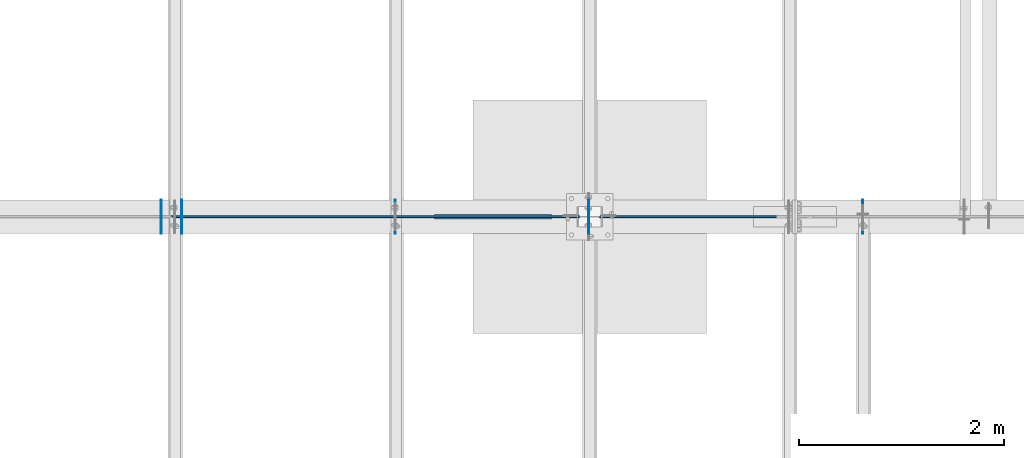
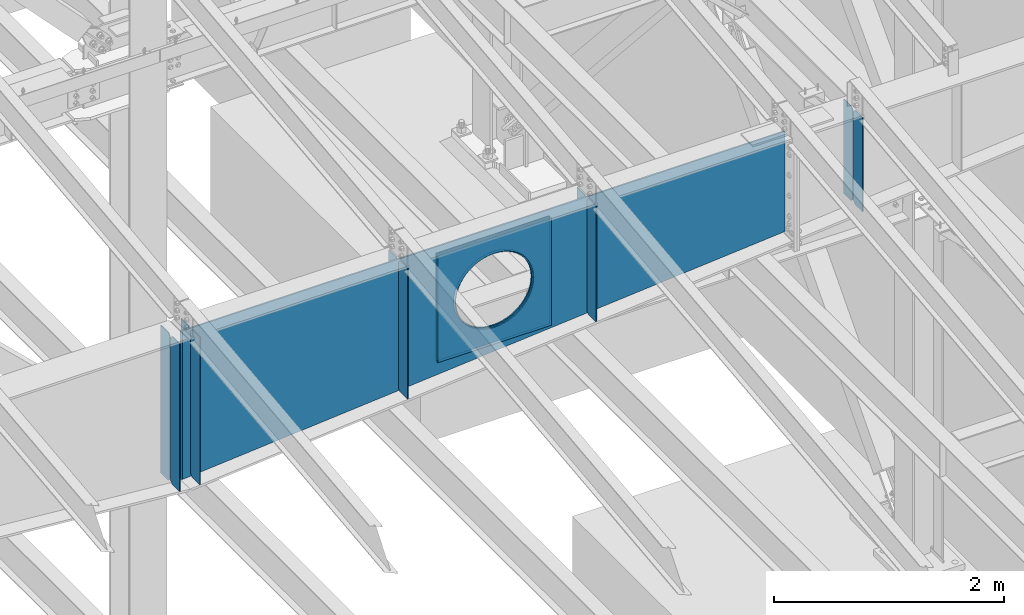
# One storey, part 974 of 1179: 13 plates, 2 elements without a shape of their own.
"""IFC2X3 building model written with IfcOpenShell, lengths in millimetres."""

from ifc_helpers import new_model, si_unit, frame, origin_with_axes, place, context, subcontext, project, spatial, faceted_brep, material, type_object, element, aggregate, save


model = new_model("IFC2X3")

# Units and contexts
model_context = context("Model", 3, precision=1e-05, world=origin_with_axes())
body_context = subcontext(model_context, "Body", "Model", "MODEL_VIEW")
ifc_project = project(units=[si_unit("LENGTHUNIT", "METRE", prefix="MILLI"), si_unit("AREAUNIT", "SQUARE_METRE"), si_unit("VOLUMEUNIT", "CUBIC_METRE"), si_unit("MASSUNIT", "GRAM", prefix="KILO"), si_unit("TIMEUNIT", "SECOND"), si_unit("PLANEANGLEUNIT", "RADIAN"), si_unit("SOLIDANGLEUNIT", "STERADIAN"), si_unit("THERMODYNAMICTEMPERATUREUNIT", "DEGREE_CELSIUS"), si_unit("LUMINOUSINTENSITYUNIT", "LUMEN")], contexts=[model_context])

# Site, building, storey
site_placement = place(None, origin_with_axes())
site = spatial("IfcSite", under=ifc_project, at=site_placement, CompositionType="ELEMENT")
building_placement = place(site_placement, origin_with_axes())
building = spatial("IfcBuilding", under=site, at=building_placement, Name="Undefined", CompositionType="ELEMENT")
storey_placement = place(building_placement, origin_with_axes())
storey = spatial("IfcBuildingStorey", under=building, at=storey_placement, Name="Undefined", CompositionType="ELEMENT", Elevation=0.0)

# Assembly, plates
assembly_1_placement = place(storey_placement, origin_with_axes())
assembly_1 = element("IfcElementAssembly", 1, at=assembly_1_placement, inside=storey, Name="RAFTER BEAM", AssemblyPlace="NOTDEFINED", PredefinedType="RIGID_FRAME")
ifc_material = material(Name="STEEL/A36")
plate_type_1 = type_object("IfcPlateType", PredefinedType="NOTDEFINED")
plate_1_placement = place(assembly_1_placement, frame((19130.9625, 19392.8999999624, 11103.7687496185), z_axis=(0.0, 0.0, -1.0), x_axis=(0.0, -1.0, 0.0)))
plate_1 = element("IfcPlate", 2, at=plate_1_placement, type_object=plate_type_1, material=ifc_material, Name="PLATE", context=body_context, shape_type="Brep", body=[
    faceted_brep([(0.0, -4.76249999999709, 0.0), (-2.26062911679037e-06, -4.76250000000073, 1000.58386493601), (-2.26062911679037e-06, 4.76250000000073, 1000.58386493601), (0.0, 4.76249999999709, 0.0), (131.762498120836, -4.76250000000073, 1000.58386525562), (131.762498120836, 4.76250000000073, 1000.58386525562), (157.162497796751, -4.76250000000073, 975.1838656987), (157.162497796751, 4.76250000000073, 975.1838656987), (157.162499942613, -4.76250000000073, 25.3999996182793), (157.162499942613, 4.76250000000073, 25.3999996182793), (131.762500381465, -4.76250000000073, -2.09183781407773e-10), (131.762500381465, 4.76250000000073, -2.09183781407773e-10)], [[[0, 1, 2, 3]], [[1, 4, 5, 2]], [[4, 6, 7, 5]], [[6, 8, 9, 7]], [[8, 10, 11, 9]], [[10, 0, 3, 11]], [[5, 7, 9, 11, 3, 2]], [[10, 8, 6, 4, 1, 0]]]),
])
plate_2_placement = place(assembly_1_placement, frame((19130.9625, 19062.6999999987, 11103.7687496185), z_axis=(0.0, 0.0, -1.0), x_axis=(0.0, 1.0, 0.0)))
plate_2 = element("IfcPlate", 3, at=plate_2_placement, type_object=plate_type_1, material=ifc_material, Name="PLATE", context=body_context, shape_type="Brep", body=[
    faceted_brep([(0.0, -4.76249999999709, 0.0), (-2.26062911679037e-06, -4.76250000000073, 1000.58386493601), (-2.26062911679037e-06, 4.76250000000073, 1000.58386493601), (0.0, 4.76249999999709, 0.0), (131.762498120836, -4.76250000000073, 1000.58386525562), (131.762498120836, 4.76250000000073, 1000.58386525562), (157.162497796751, -4.76250000000073, 975.1838656987), (157.162497796751, 4.76250000000073, 975.1838656987), (157.162499942613, -4.76250000000073, 25.3999996182793), (157.162499942613, 4.76250000000073, 25.3999996182793), (131.762500381465, -4.76250000000073, -2.09183781407773e-10), (131.762500381465, 4.76250000000073, -2.09183781407773e-10)], [[[0, 1, 2, 3]], [[1, 4, 5, 2]], [[4, 6, 7, 5]], [[6, 8, 9, 7]], [[8, 10, 11, 9]], [[10, 0, 3, 11]], [[5, 7, 9, 11, 3, 2]], [[10, 8, 6, 4, 1, 0]]]),
])
aggregate(assembly_1, [plate_1, plate_2])

assembly_2_placement = place(storey_placement, origin_with_axes())
assembly_2 = element("IfcElementAssembly", 4, at=assembly_2_placement, inside=storey, Name="RAFTER BEAM", AssemblyPlace="NOTDEFINED", PredefinedType="RIGID_FRAME")
plate_3_placement = place(assembly_2_placement, frame((14558.9625, 19392.8999999624, 11103.7687496185), z_axis=(0.0, 0.0, -1.0), x_axis=(0.0, -1.0, 0.0)))
plate_3 = element("IfcPlate", 5, at=plate_3_placement, type_object=plate_type_1, material=ifc_material, Name="PLATE", context=body_context, shape_type="Brep", body=[
    faceted_brep([(0.0, -4.76249999999709, 0.0), (-3.04256900562905e-06, -4.76250000000073, 1391.55413132619), (-3.04256900562905e-06, 4.76250000000073, 1391.55413132619), (0.0, 4.76249999999709, 0.0), (131.762497338896, -4.76250000000073, 1391.5541316458), (131.762497338896, 4.76250000000073, 1391.5541316458), (157.162497012963, -4.76250000000073, 1366.15413208888), (157.162497012963, 4.76250000000073, 1366.15413208888), (157.162499942613, -4.76250000000073, 25.3999996182793), (157.162499942613, 4.76250000000073, 25.3999996182793), (131.762500381465, -4.76250000000073, -2.09183781407773e-10), (131.762500381465, 4.76250000000073, -2.09183781407773e-10)], [[[0, 1, 2, 3]], [[1, 4, 5, 2]], [[4, 6, 7, 5]], [[6, 8, 9, 7]], [[8, 10, 11, 9]], [[10, 0, 3, 11]], [[5, 7, 9, 11, 3, 2]], [[10, 8, 6, 4, 1, 0]]]),
])
plate_4_placement = place(assembly_2_placement, frame((16451.2625, 19392.8999999624, 11103.7687496185), z_axis=(0.0, 0.0, -1.0), x_axis=(0.0, -1.0, 0.0)))
plate_4 = element("IfcPlate", 6, at=plate_4_placement, type_object=plate_type_1, material=ifc_material, Name="PLATE", context=body_context, shape_type="Brep", body=[
    faceted_brep([(0.0, -4.76249999999709, 0.0), (-2.72028773906641e-06, -4.76250000000073, 1230.41295070648), (-2.72028773906641e-06, 4.76250000000073, 1230.41295070648), (0.0, 4.76249999999709, 0.0), (131.762497661177, -4.76250000000073, 1230.41295102609), (131.762497661177, 4.76250000000073, 1230.41295102609), (157.162497335859, -4.76250000000073, 1205.01295146917), (157.162497335859, 4.76250000000073, 1205.01295146917), (157.162499942613, -4.76250000000073, 25.3999996182793), (157.162499942613, 4.76250000000073, 25.3999996182793), (131.762500381465, -4.76250000000073, -2.09183781407773e-10), (131.762500381465, 4.76250000000073, -2.09183781407773e-10)], [[[0, 1, 2, 3]], [[1, 4, 5, 2]], [[4, 6, 7, 5]], [[6, 8, 9, 7]], [[8, 10, 11, 9]], [[10, 0, 3, 11]], [[5, 7, 9, 11, 3, 2]], [[10, 8, 6, 4, 1, 0]]]),
])
plate_5_placement = place(assembly_2_placement, frame((14558.9625, 19062.6999999987, 11103.7687496185), z_axis=(0.0, 0.0, -1.0), x_axis=(0.0, 1.0, 0.0)))
plate_5 = element("IfcPlate", 7, at=plate_5_placement, type_object=plate_type_1, material=ifc_material, Name="PLATE", context=body_context, shape_type="Brep", body=[
    faceted_brep([(0.0, -4.76249999999709, 0.0), (-3.04256900562905e-06, -4.76250000000073, 1391.55413132619), (-3.04256900562905e-06, 4.76250000000073, 1391.55413132619), (0.0, 4.76249999999709, 0.0), (131.762497338896, -4.76250000000073, 1391.5541316458), (131.762497338896, 4.76250000000073, 1391.5541316458), (157.162497012963, -4.76250000000073, 1366.15413208888), (157.162497012963, 4.76250000000073, 1366.15413208888), (157.162499942613, -4.76250000000073, 25.3999996182793), (157.162499942613, 4.76250000000073, 25.3999996182793), (131.762500381465, -4.76250000000073, -2.09183781407773e-10), (131.762500381465, 4.76250000000073, -2.09183781407773e-10)], [[[0, 1, 2, 3]], [[1, 4, 5, 2]], [[4, 6, 7, 5]], [[6, 8, 9, 7]], [[8, 10, 11, 9]], [[10, 0, 3, 11]], [[5, 7, 9, 11, 3, 2]], [[10, 8, 6, 4, 1, 0]]]),
])
plate_6_placement = place(assembly_2_placement, frame((16451.2625, 19062.6999999987, 11103.7687496185), z_axis=(0.0, 0.0, -1.0), x_axis=(0.0, 1.0, 0.0)))
plate_6 = element("IfcPlate", 8, at=plate_6_placement, type_object=plate_type_1, material=ifc_material, Name="PLATE", context=body_context, shape_type="Brep", body=[
    faceted_brep([(0.0, -4.76249999999709, 0.0), (-2.72028773906641e-06, -4.76250000000073, 1230.41295070648), (-2.72028773906641e-06, 4.76250000000073, 1230.41295070648), (0.0, 4.76249999999709, 0.0), (131.762497661177, -4.76250000000073, 1230.41295102609), (131.762497661177, 4.76250000000073, 1230.41295102609), (157.162497335859, -4.76250000000073, 1205.01295146917), (157.162497335859, 4.76250000000073, 1205.01295146917), (157.162499942613, -4.76250000000073, 25.3999996182793), (157.162499942613, 4.76250000000073, 25.3999996182793), (131.762500381465, -4.76250000000073, -2.09183781407773e-10), (131.762500381465, 4.76250000000073, -2.09183781407773e-10)], [[[0, 1, 2, 3]], [[1, 4, 5, 2]], [[4, 6, 7, 5]], [[6, 8, 9, 7]], [[8, 10, 11, 9]], [[10, 0, 3, 11]], [[5, 7, 9, 11, 3, 2]], [[10, 8, 6, 4, 1, 0]]]),
])
plate_7_placement = place(assembly_2_placement, frame((12471.4000000016, 19235.7374938951, 11103.7721309662), z_axis=(0.0, 0.0, -1.0), x_axis=(0.0, 1.0, 0.0)))
plate_7 = element("IfcPlate", 9, at=plate_7_placement, type_object=plate_type_1, material=ifc_material, Name="PLATE", context=body_context, shape_type="Brep", body=[
    faceted_brep([(0.0, -4.76250000000073, 25.3999996185303), (0.0, -4.76250000000073, 1543.92653032954), (0.0, 4.76250000000073, 1543.92653032954), (0.0, 4.76250000000073, 25.3999996185303), (25.3999996185303, -4.76250000000073, 1569.32652994807), (25.3999996185303, 4.76250000000073, 1569.32652994807), (157.162506103516, -4.76250000000073, 1569.32652994807), (157.162506103516, 4.76250000000073, 1569.32652994807), (157.162506103516, -4.76250000000073, 0.0), (157.162506103516, 4.76250000000073, 0.0), (25.3999996185303, -4.76250000000073, 0.0), (25.3999996185303, 4.76250000000073, 0.0)], [[[0, 1, 2, 3]], [[1, 4, 5, 2]], [[4, 6, 7, 5]], [[6, 8, 9, 7]], [[8, 10, 11, 9]], [[10, 0, 3, 11]], [[5, 7, 9, 11, 3, 2]], [[10, 8, 6, 4, 1, 0]]]),
])
plate_8_placement = place(assembly_2_placement, frame((12471.4000000016, 19219.8625061022, 11103.7721309662), z_axis=(0.0, 0.0, -1.0), x_axis=(0.0, -1.0, 0.0)))
plate_8 = element("IfcPlate", 10, at=plate_8_placement, type_object=plate_type_1, material=ifc_material, Name="PLATE", context=body_context, shape_type="Brep", body=[
    faceted_brep([(0.0, -4.76250000000073, 25.3999996185303), (0.0, -4.76250000000073, 1543.92653032954), (0.0, 4.76250000000073, 1543.92653032954), (0.0, 4.76250000000073, 25.3999996185303), (25.3999996185303, -4.76250000000073, 1569.32652994807), (25.3999996185303, 4.76250000000073, 1569.32652994807), (157.162506103516, -4.76250000000073, 1569.32652994807), (157.162506103516, 4.76250000000073, 1569.32652994807), (157.162506103516, -4.76250000000073, 0.0), (157.162506103516, 4.76250000000073, 0.0), (25.3999996185303, -4.76250000000073, 0.0), (25.3999996185303, 4.76250000000073, 0.0)], [[[0, 1, 2, 3]], [[1, 4, 5, 2]], [[4, 6, 7, 5]], [[6, 8, 9, 7]], [[8, 10, 11, 9]], [[10, 0, 3, 11]], [[5, 7, 9, 11, 3, 2]], [[10, 8, 6, 4, 1, 0]]]),
])
plate_9_placement = place(assembly_2_placement, frame((12268.2000000016, 19235.7374877916, 11103.7721309662), z_axis=(0.0, 0.0, -1.0), x_axis=(0.0, 1.0, 0.0)))
plate_9 = element("IfcPlate", 11, at=plate_9_placement, type_object=plate_type_1, material=ifc_material, Name="PLATE", context=body_context, shape_type="Brep", body=[
    faceted_brep([(0.0, -4.76250000000073, 25.3999996185303), (0.0, -4.76250000000073, 1543.92653032954), (0.0, 4.76250000000073, 1543.92653032954), (0.0, 4.76250000000073, 25.3999996185303), (25.3999996185303, -4.76250000000073, 1569.32652994807), (25.3999996185303, 4.76250000000073, 1569.32652994807), (157.162506103516, -4.76250000000073, 1569.32652994807), (157.162506103516, 4.76250000000073, 1569.32652994807), (157.162506103516, -4.76250000000073, 0.0), (157.162506103516, 4.76250000000073, 0.0), (25.3999996185303, -4.76250000000073, 0.0), (25.3999996185303, 4.76250000000073, 0.0)], [[[0, 1, 2, 3]], [[1, 4, 5, 2]], [[4, 6, 7, 5]], [[6, 8, 9, 7]], [[8, 10, 11, 9]], [[10, 0, 3, 11]], [[5, 7, 9, 11, 3, 2]], [[10, 8, 6, 4, 1, 0]]]),
])
plate_10_placement = place(assembly_2_placement, frame((12268.2000000016, 19219.8624999987, 11103.7721309662), z_axis=(0.0, 0.0, -1.0), x_axis=(0.0, -1.0, 0.0)))
plate_10 = element("IfcPlate", 12, at=plate_10_placement, type_object=plate_type_1, material=ifc_material, Name="PLATE", context=body_context, shape_type="Brep", body=[
    faceted_brep([(0.0, -4.76250000000073, 25.3999996185303), (0.0, -4.76250000000073, 1543.92653032954), (0.0, 4.76250000000073, 1543.92653032954), (0.0, 4.76250000000073, 25.3999996185303), (25.3999996185303, -4.76250000000073, 1569.32652994807), (25.3999996185303, 4.76250000000073, 1569.32652994807), (157.162506103516, -4.76250000000073, 1569.32652994807), (157.162506103516, 4.76250000000073, 1569.32652994807), (157.162506103516, -4.76250000000073, 0.0), (157.162506103516, 4.76250000000073, 0.0), (25.3999996185303, -4.76250000000073, 0.0), (25.3999996185303, 4.76250000000073, 0.0)], [[[0, 1, 2, 3]], [[1, 4, 5, 2]], [[4, 6, 7, 5]], [[6, 8, 9, 7]], [[8, 10, 11, 9]], [[10, 0, 3, 11]], [[5, 7, 9, 11, 3, 2]], [[10, 8, 6, 4, 1, 0]]]),
])
plate_type_2 = type_object("IfcPlateType", PredefinedType="NOTDEFINED")
plate_11_placement = place(assembly_2_placement, frame((16084.55, 19242.0874999987, 11020.1149414063), z_axis=(0.0, 0.0, -1.0), x_axis=(-1.0, 0.0, 0.0)))
plate_11 = element("IfcPlate", 13, at=plate_11_placement, type_object=plate_type_2, material=ifc_material, Name="PLATE", context=body_context, shape_type="Brep", body=[
    faceted_brep([(961.831841922869, -6.35000000000036, 520.111838122966), (961.831841922869, 6.35000000000036, 520.111838122966), (951.784997810006, 6.35000000000036, 469.602941943138), (951.784997810006, -6.35000000000036, 469.602941943138), (935.231371949694, 6.35000000000036, 420.837532677864), (935.231371949694, -6.35000000000036, 420.837532677864), (912.454201469933, 6.35000000000036, 374.65), (912.454201469933, -6.35000000000036, 374.65), (883.843210072659, 6.35000000000036, 331.830625399267), (883.843210072659, -6.35000000000036, 331.830625399267), (849.887939753144, 6.35000000000036, 293.112060246856), (849.887939753144, -6.35000000000036, 293.112060246856), (811.169374600733, 6.35000000000036, 259.156789927341), (811.169374600733, -6.35000000000036, 259.156789927341), (768.35, 6.35000000000036, 230.545798530067), (768.35, -6.35000000000036, 230.545798530067), (722.162467322136, 6.35000000000036, 207.768628050306), (722.162467322136, -6.35000000000036, 207.768628050306), (673.397058056862, 6.35000000000036, 191.215002189994), (673.397058056862, -6.35000000000036, 191.215002189994), (622.888161877034, 6.35000000000036, 181.168158077131), (622.888161877034, -6.35000000000036, 181.168158077131), (571.5, 6.35000000000036, 177.799999999999), (571.5, -6.35000000000036, 177.799999999999), (520.111838122966, 6.35000000000036, 181.168158077131), (520.111838122966, -6.35000000000036, 181.168158077131), (469.602941943138, 6.35000000000036, 191.215002189994), (469.602941943138, -6.35000000000036, 191.215002189994), (420.837532677864, 6.35000000000036, 207.768628050306), (420.837532677864, -6.35000000000036, 207.768628050306), (374.65, 6.35000000000036, 230.545798530067), (374.65, -6.35000000000036, 230.545798530067), (331.830625399267, 6.35000000000036, 259.156789927341), (331.830625399267, -6.35000000000036, 259.156789927341), (293.112060246856, 6.35000000000036, 293.112060246856), (293.112060246856, -6.35000000000036, 293.112060246856), (259.156789927341, 6.35000000000036, 331.830625399267), (259.156789927341, -6.35000000000036, 331.830625399267), (230.545798530067, 6.35000000000036, 374.65), (230.545798530067, -6.35000000000036, 374.65), (207.768628050306, 6.35000000000036, 420.837532677864), (207.768628050306, -6.35000000000036, 420.837532677864), (191.215002189994, 6.35000000000036, 469.602941943138), (191.215002189994, -6.35000000000036, 469.602941943138), (181.168158077131, 6.35000000000036, 520.111838122966), (181.168158077131, -6.35000000000036, 520.111838122966), (177.799999999999, 6.35000000000036, 571.5), (177.799999999999, -6.35000000000036, 571.5), (181.168158077131, 6.35000000000036, 622.888161877036), (181.168158077131, -6.35000000000036, 622.888161877036), (191.215002189994, 6.35000000000036, 673.397058056862), (191.215002189994, -6.35000000000036, 673.397058056862), (207.768628050306, 6.35000000000036, 722.162467322136), (207.768628050306, -6.35000000000036, 722.162467322136), (230.545798530067, 6.35000000000036, 768.35), (230.545798530067, -6.35000000000036, 768.35), (259.156789927341, 6.35000000000036, 811.169374600733), (259.156789927341, -6.35000000000036, 811.169374600733), (293.112060246856, 6.35000000000036, 849.887939753144), (293.112060246856, -6.35000000000036, 849.887939753144), (331.830625399267, 6.35000000000036, 883.84321007266), (331.830625399267, -6.35000000000036, 883.84321007266), (374.65, 6.35000000000036, 912.454201469933), (374.65, -6.35000000000036, 912.454201469933), (420.837532677864, 6.35000000000036, 935.231371949694), (420.837532677864, -6.35000000000036, 935.231371949694), (469.602941943138, 6.35000000000036, 951.784997810006), (469.602941943138, -6.35000000000036, 951.784997810006), (520.111838122966, 6.35000000000036, 961.831841922869), (520.111838122966, -6.35000000000036, 961.831841922869), (571.5, 6.35000000000036, 965.200000000001), (571.5, -6.35000000000036, 965.200000000001), (622.888161877034, 6.35000000000036, 961.831841922869), (622.888161877034, -6.35000000000036, 961.831841922869), (673.397058056862, 6.35000000000036, 951.784997810006), (673.397058056862, -6.35000000000036, 951.784997810006), (722.162467322136, 6.35000000000036, 935.231371949694), (722.162467322136, -6.35000000000036, 935.231371949694), (768.35, 6.35000000000036, 912.454201469933), (768.35, -6.35000000000036, 912.454201469933), (811.169374600733, 6.35000000000036, 883.843210072659), (811.169374600733, -6.35000000000036, 883.843210072659), (849.887939753144, 6.35000000000036, 849.887939753144), (849.887939753144, -6.35000000000036, 849.887939753144), (883.843210072659, 6.35000000000036, 811.169374600733), (883.843210072659, -6.35000000000036, 811.169374600733), (912.454201469933, 6.35000000000036, 768.35), (912.454201469933, -6.35000000000036, 768.35), (935.231371949694, 6.35000000000036, 722.162467322136), (935.231371949694, -6.35000000000036, 722.162467322136), (951.784997810006, 6.35000000000036, 673.397058056862), (951.784997810006, -6.35000000000036, 673.397058056862), (961.831841922869, 6.35000000000036, 622.888161877034), (961.831841922869, -6.35000000000036, 622.888161877034), (965.200000000001, 6.35000000000036, 571.5), (965.200000000001, -6.35000000000036, 571.5), (1143.0, -6.35000000000036, 0.0), (1143.0, -6.35000000000036, 1143.0), (0.0, -6.35000000000036, 1143.0), (0.0, -6.34999999999854, 0.0), (0.0, 6.34999999999854, 0.0), (1143.0, 6.35000000000036, 0.0), (1143.0, 6.35000000000036, 1143.0), (0.0, 6.35000000000036, 1143.0)], [[[0, 1, 2, 3]], [[3, 2, 4, 5]], [[5, 4, 6, 7]], [[7, 6, 8, 9]], [[9, 8, 10, 11]], [[11, 10, 12, 13]], [[13, 12, 14, 15]], [[15, 14, 16, 17]], [[17, 16, 18, 19]], [[19, 18, 20, 21]], [[21, 20, 22, 23]], [[23, 22, 24, 25]], [[25, 24, 26, 27]], [[27, 26, 28, 29]], [[29, 28, 30, 31]], [[31, 30, 32, 33]], [[33, 32, 34, 35]], [[35, 34, 36, 37]], [[37, 36, 38, 39]], [[39, 38, 40, 41]], [[41, 40, 42, 43]], [[43, 42, 44, 45]], [[45, 44, 46, 47]], [[47, 46, 48, 49]], [[49, 48, 50, 51]], [[51, 50, 52, 53]], [[53, 52, 54, 55]], [[55, 54, 56, 57]], [[57, 56, 58, 59]], [[59, 58, 60, 61]], [[61, 60, 62, 63]], [[63, 62, 64, 65]], [[65, 64, 66, 67]], [[67, 66, 68, 69]], [[69, 68, 70, 71]], [[71, 70, 72, 73]], [[73, 72, 74, 75]], [[75, 74, 76, 77]], [[77, 76, 78, 79]], [[79, 78, 80, 81]], [[81, 80, 82, 83]], [[83, 82, 84, 85]], [[85, 84, 86, 87]], [[87, 86, 88, 89]], [[89, 88, 90, 91]], [[91, 90, 92, 93]], [[93, 92, 94, 95]], [[95, 94, 1, 0]], [[96, 97, 98, 99], [3, 5, 7, 9, 11, 13, 15, 17, 19, 21, 23, 25, 27, 29, 31, 33, 35, 37, 39, 41, 43, 45, 47, 49, 51, 53, 55, 57, 59, 61, 63, 65, 67, 69, 71, 73, 75, 77, 79, 81, 83, 85, 87, 89, 91, 93, 95, 0]], [[96, 99, 100, 101]], [[97, 96, 101, 102]], [[98, 97, 102, 103]], [[99, 98, 103, 100]], [[102, 101, 100, 103], [90, 88, 86, 84, 82, 80, 78, 76, 74, 72, 70, 68, 66, 64, 62, 60, 58, 56, 54, 52, 50, 48, 46, 44, 42, 40, 38, 36, 34, 32, 30, 28, 26, 24, 22, 20, 18, 16, 14, 12, 10, 8, 6, 4, 2, 1, 94, 92]]]),
])
plate_12_placement = place(assembly_2_placement, frame((16084.55, 19213.5124999987, 11020.1149414063), z_axis=(0.0, 0.0, -1.0), x_axis=(-1.0, 0.0, 0.0)))
plate_12 = element("IfcPlate", 14, at=plate_12_placement, type_object=plate_type_2, material=ifc_material, Name="PLATE", context=body_context, shape_type="Brep", body=[
    faceted_brep([(961.831841922869, -6.35000000000036, 520.111838122966), (961.831841922869, 6.35000000000036, 520.111838122966), (951.784997810006, 6.35000000000036, 469.602941943138), (951.784997810006, -6.35000000000036, 469.602941943138), (935.231371949694, 6.35000000000036, 420.837532677864), (935.231371949694, -6.35000000000036, 420.837532677864), (912.454201469933, 6.35000000000036, 374.65), (912.454201469933, -6.35000000000036, 374.65), (883.843210072659, 6.35000000000036, 331.830625399267), (883.843210072659, -6.35000000000036, 331.830625399267), (849.887939753144, 6.35000000000036, 293.112060246856), (849.887939753144, -6.35000000000036, 293.112060246856), (811.169374600733, 6.35000000000036, 259.156789927341), (811.169374600733, -6.35000000000036, 259.156789927341), (768.35, 6.35000000000036, 230.545798530067), (768.35, -6.35000000000036, 230.545798530067), (722.162467322136, 6.35000000000036, 207.768628050306), (722.162467322136, -6.35000000000036, 207.768628050306), (673.397058056862, 6.35000000000036, 191.215002189994), (673.397058056862, -6.35000000000036, 191.215002189994), (622.888161877034, 6.35000000000036, 181.168158077131), (622.888161877034, -6.35000000000036, 181.168158077131), (571.5, 6.35000000000036, 177.799999999999), (571.5, -6.35000000000036, 177.799999999999), (520.111838122966, 6.35000000000036, 181.168158077131), (520.111838122966, -6.35000000000036, 181.168158077131), (469.602941943138, 6.35000000000036, 191.215002189994), (469.602941943138, -6.35000000000036, 191.215002189994), (420.837532677864, 6.35000000000036, 207.768628050306), (420.837532677864, -6.35000000000036, 207.768628050306), (374.65, 6.35000000000036, 230.545798530067), (374.65, -6.35000000000036, 230.545798530067), (331.830625399267, 6.35000000000036, 259.156789927341), (331.830625399267, -6.35000000000036, 259.156789927341), (293.112060246856, 6.35000000000036, 293.112060246856), (293.112060246856, -6.35000000000036, 293.112060246856), (259.156789927341, 6.35000000000036, 331.830625399267), (259.156789927341, -6.35000000000036, 331.830625399267), (230.545798530067, 6.35000000000036, 374.65), (230.545798530067, -6.35000000000036, 374.65), (207.768628050306, 6.35000000000036, 420.837532677864), (207.768628050306, -6.35000000000036, 420.837532677864), (191.215002189994, 6.35000000000036, 469.602941943138), (191.215002189994, -6.35000000000036, 469.602941943138), (181.168158077131, 6.35000000000036, 520.111838122966), (181.168158077131, -6.35000000000036, 520.111838122966), (177.799999999999, 6.35000000000036, 571.5), (177.799999999999, -6.35000000000036, 571.5), (181.168158077131, 6.35000000000036, 622.888161877036), (181.168158077131, -6.35000000000036, 622.888161877036), (191.215002189994, 6.35000000000036, 673.397058056862), (191.215002189994, -6.35000000000036, 673.397058056862), (207.768628050306, 6.35000000000036, 722.162467322136), (207.768628050306, -6.35000000000036, 722.162467322136), (230.545798530067, 6.35000000000036, 768.35), (230.545798530067, -6.35000000000036, 768.35), (259.156789927341, 6.35000000000036, 811.169374600733), (259.156789927341, -6.35000000000036, 811.169374600733), (293.112060246856, 6.35000000000036, 849.887939753144), (293.112060246856, -6.35000000000036, 849.887939753144), (331.830625399267, 6.35000000000036, 883.84321007266), (331.830625399267, -6.35000000000036, 883.84321007266), (374.65, 6.35000000000036, 912.454201469933), (374.65, -6.35000000000036, 912.454201469933), (420.837532677864, 6.35000000000036, 935.231371949694), (420.837532677864, -6.35000000000036, 935.231371949694), (469.602941943138, 6.35000000000036, 951.784997810006), (469.602941943138, -6.35000000000036, 951.784997810006), (520.111838122966, 6.35000000000036, 961.831841922869), (520.111838122966, -6.35000000000036, 961.831841922869), (571.5, 6.35000000000036, 965.200000000001), (571.5, -6.35000000000036, 965.200000000001), (622.888161877034, 6.35000000000036, 961.831841922869), (622.888161877034, -6.35000000000036, 961.831841922869), (673.397058056862, 6.35000000000036, 951.784997810006), (673.397058056862, -6.35000000000036, 951.784997810006), (722.162467322136, 6.35000000000036, 935.231371949694), (722.162467322136, -6.35000000000036, 935.231371949694), (768.35, 6.35000000000036, 912.454201469933), (768.35, -6.35000000000036, 912.454201469933), (811.169374600733, 6.35000000000036, 883.843210072659), (811.169374600733, -6.35000000000036, 883.843210072659), (849.887939753144, 6.35000000000036, 849.887939753144), (849.887939753144, -6.35000000000036, 849.887939753144), (883.843210072659, 6.35000000000036, 811.169374600733), (883.843210072659, -6.35000000000036, 811.169374600733), (912.454201469933, 6.35000000000036, 768.35), (912.454201469933, -6.35000000000036, 768.35), (935.231371949694, 6.35000000000036, 722.162467322136), (935.231371949694, -6.35000000000036, 722.162467322136), (951.784997810006, 6.35000000000036, 673.397058056862), (951.784997810006, -6.35000000000036, 673.397058056862), (961.831841922869, 6.35000000000036, 622.888161877034), (961.831841922869, -6.35000000000036, 622.888161877034), (965.200000000001, 6.35000000000036, 571.5), (965.200000000001, -6.35000000000036, 571.5), (1143.0, -6.35000000000036, 0.0), (1143.0, -6.35000000000036, 1143.0), (0.0, -6.35000000000036, 1143.0), (0.0, -6.34999999999854, 0.0), (0.0, 6.34999999999854, 0.0), (1143.0, 6.35000000000036, 0.0), (1143.0, 6.35000000000036, 1143.0), (0.0, 6.35000000000036, 1143.0)], [[[0, 1, 2, 3]], [[3, 2, 4, 5]], [[5, 4, 6, 7]], [[7, 6, 8, 9]], [[9, 8, 10, 11]], [[11, 10, 12, 13]], [[13, 12, 14, 15]], [[15, 14, 16, 17]], [[17, 16, 18, 19]], [[19, 18, 20, 21]], [[21, 20, 22, 23]], [[23, 22, 24, 25]], [[25, 24, 26, 27]], [[27, 26, 28, 29]], [[29, 28, 30, 31]], [[31, 30, 32, 33]], [[33, 32, 34, 35]], [[35, 34, 36, 37]], [[37, 36, 38, 39]], [[39, 38, 40, 41]], [[41, 40, 42, 43]], [[43, 42, 44, 45]], [[45, 44, 46, 47]], [[47, 46, 48, 49]], [[49, 48, 50, 51]], [[51, 50, 52, 53]], [[53, 52, 54, 55]], [[55, 54, 56, 57]], [[57, 56, 58, 59]], [[59, 58, 60, 61]], [[61, 60, 62, 63]], [[63, 62, 64, 65]], [[65, 64, 66, 67]], [[67, 66, 68, 69]], [[69, 68, 70, 71]], [[71, 70, 72, 73]], [[73, 72, 74, 75]], [[75, 74, 76, 77]], [[77, 76, 78, 79]], [[79, 78, 80, 81]], [[81, 80, 82, 83]], [[83, 82, 84, 85]], [[85, 84, 86, 87]], [[87, 86, 88, 89]], [[89, 88, 90, 91]], [[91, 90, 92, 93]], [[93, 92, 94, 95]], [[95, 94, 1, 0]], [[96, 97, 98, 99], [3, 5, 7, 9, 11, 13, 15, 17, 19, 21, 23, 25, 27, 29, 31, 33, 35, 37, 39, 41, 43, 45, 47, 49, 51, 53, 55, 57, 59, 61, 63, 65, 67, 69, 71, 73, 75, 77, 79, 81, 83, 85, 87, 89, 91, 93, 95, 0]], [[96, 99, 100, 101]], [[97, 96, 101, 102]], [[98, 97, 102, 103]], [[99, 98, 103, 100]], [[102, 101, 100, 103], [90, 88, 86, 84, 82, 80, 78, 76, 74, 72, 70, 68, 66, 64, 62, 60, 58, 56, 54, 52, 50, 48, 46, 44, 42, 40, 38, 36, 34, 32, 30, 28, 26, 24, 22, 20, 18, 16, 14, 12, 10, 8, 6, 4, 2, 1, 94, 92]]]),
])
plate_type_3 = type_object("IfcPlateType", PredefinedType="NOTDEFINED")
plate_13_placement = place(assembly_2_placement, frame((18465.8, 19227.7999999987, 11105.3562496185), z_axis=(0.0, 0.0, -1.0), x_axis=(-1.0, 0.0, 0.0)))
plate_13 = element("IfcPlate", 15, at=plate_13_placement, type_object=plate_type_3, material=ifc_material, Name="RAFTER BEAM", context=body_context, shape_type="Brep", body=[
    faceted_brep([(3330.49049218342, -7.9375, 607.010828976441), (3330.49049218342, 7.9375, 607.010828976441), (3320.76773981614, 7.9375, 558.131252028219), (3320.76773981614, -7.9375, 558.131252028219), (3304.7481018868, 7.9375, 510.938920481181), (3304.7481018868, -7.9375, 510.938920481181), (3282.70567884187, 7.9375, 466.24130821228), (3282.70567884187, -7.9375, 466.24130821228), (3255.01762265096, 7.9375, 424.803203759957), (3255.01762265096, -7.9375, 424.803203759957), (3222.15768363208, 7.9375, 387.333624580206), (3222.15768363208, -7.9375, 387.333624580206), (3184.68810445233, 7.9375, 354.473685561319), (3184.68810445233, -7.9375, 354.473685561319), (3143.25, 7.9375, 326.78562937041), (3143.25, -7.9375, 326.78562937041), (3098.5523877311, 7.9375, 304.74320632548), (3098.5523877311, -7.9375, 304.74320632548), (3051.36005618406, 7.9375, 288.723568396144), (3051.36005618406, -7.9375, 288.723568396144), (3002.48047923584, 7.9375, 279.000816028858), (3002.48047923584, -7.9375, 279.000816028858), (2952.75, 7.9375, 275.74130821228), (2952.75, -7.9375, 275.74130821228), (2903.01952076416, 7.9375, 279.000816028858), (2903.01952076416, -7.9375, 279.000816028858), (2854.13994381594, 7.9375, 288.723568396144), (2854.13994381594, -7.9375, 288.723568396144), (2806.9476122689, 7.9375, 304.74320632548), (2806.9476122689, -7.9375, 304.74320632548), (2762.25, 7.9375, 326.78562937041), (2762.25, -7.9375, 326.78562937041), (2720.81189554768, 7.9375, 354.473685561319), (2720.81189554768, -7.9375, 354.473685561319), (2683.34231636793, 7.9375, 387.333624580206), (2683.34231636793, -7.9375, 387.333624580206), (2650.48237734904, 7.9375, 424.803203759957), (2650.48237734904, -7.9375, 424.803203759957), (2622.79432115813, 7.9375, 466.24130821228), (2622.79432115813, -7.9375, 466.24130821228), (2600.7518981132, 7.9375, 510.938920481181), (2600.7518981132, -7.9375, 510.938920481181), (2584.73226018387, 7.9375, 558.131252028219), (2584.73226018387, -7.9375, 558.131252028219), (2575.00950781658, 7.9375, 607.010828976441), (2575.00950781658, -7.9375, 607.010828976441), (2571.75, 7.9375, 656.74130821228), (2571.75, -7.9375, 656.74130821228), (2575.00950781658, 7.9375, 706.471787448121), (2575.00950781658, -7.9375, 706.471787448121), (2584.73226018387, 7.9375, 755.351364396342), (2584.73226018387, -7.9375, 755.351364396342), (2600.7518981132, 7.9375, 802.543695943379), (2600.7518981132, -7.9375, 802.543695943379), (2622.79432115813, 7.9375, 847.24130821228), (2622.79432115813, -7.9375, 847.24130821228), (2650.48237734904, 7.9375, 888.679412664604), (2650.48237734904, -7.9375, 888.679412664604), (2683.34231636793, 7.9375, 926.148991844355), (2683.34231636793, -7.9375, 926.148991844355), (2720.81189554768, 7.9375, 959.008930863241), (2720.81189554768, -7.9375, 959.008930863241), (2762.25, 7.9375, 986.696987054151), (2762.25, -7.9375, 986.696987054151), (2806.9476122689, 7.9375, 1008.73941009908), (2806.9476122689, -7.9375, 1008.73941009908), (2854.13994381594, 7.9375, 1024.75904802842), (2854.13994381594, -7.9375, 1024.75904802842), (2903.01952076416, 7.9375, 1034.4818003957), (2903.01952076416, -7.9375, 1034.4818003957), (2952.75, 7.9375, 1037.74130821228), (2952.75, -7.9375, 1037.74130821228), (3002.48047923584, 7.9375, 1034.4818003957), (3002.48047923584, -7.9375, 1034.4818003957), (3051.36005618406, 7.9375, 1024.75904802842), (3051.36005618406, -7.9375, 1024.75904802842), (3098.5523877311, 7.9375, 1008.73941009908), (3098.5523877311, -7.9375, 1008.73941009908), (3143.25, 7.9375, 986.696987054151), (3143.25, -7.9375, 986.696987054151), (3184.68810445233, 7.9375, 959.008930863241), (3184.68810445233, -7.9375, 959.008930863241), (3222.15768363208, 7.9375, 926.148991844355), (3222.15768363208, -7.9375, 926.148991844355), (3255.01762265096, 7.9375, 888.679412664602), (3255.01762265096, -7.9375, 888.679412664602), (3282.70567884187, 7.9375, 847.24130821228), (3282.70567884187, -7.9375, 847.24130821228), (3304.7481018868, 7.9375, 802.543695943379), (3304.7481018868, -7.9375, 802.543695943379), (3320.76773981614, 7.9375, 755.35136439634), (3320.76773981614, -7.9375, 755.35136439634), (3330.49049218342, 7.9375, 706.471787448119), (3330.49049218342, -7.9375, 706.471787448119), (3333.75, 7.9375, 656.74130821228), (3333.75, -7.9375, 656.74130821228), (6080.125, -7.9375, 0.0), (6080.125, -7.9375, 1579.79816881816), (25.3999999990338, -7.9375, 1064.20044453931), (25.4000000002561, -7.9375, 0.0), (6096.0, 7.9375, 0.0), (25.4000000002561, 7.9375, 0.0), (6096.0, 7.9375, 1581.15002441406), (25.3999999990338, 7.9375, 1064.20044453931)], [[[0, 1, 2, 3]], [[3, 2, 4, 5]], [[5, 4, 6, 7]], [[7, 6, 8, 9]], [[9, 8, 10, 11]], [[11, 10, 12, 13]], [[13, 12, 14, 15]], [[15, 14, 16, 17]], [[17, 16, 18, 19]], [[19, 18, 20, 21]], [[21, 20, 22, 23]], [[23, 22, 24, 25]], [[25, 24, 26, 27]], [[27, 26, 28, 29]], [[29, 28, 30, 31]], [[31, 30, 32, 33]], [[33, 32, 34, 35]], [[35, 34, 36, 37]], [[37, 36, 38, 39]], [[39, 38, 40, 41]], [[41, 40, 42, 43]], [[43, 42, 44, 45]], [[45, 44, 46, 47]], [[47, 46, 48, 49]], [[49, 48, 50, 51]], [[51, 50, 52, 53]], [[53, 52, 54, 55]], [[55, 54, 56, 57]], [[57, 56, 58, 59]], [[59, 58, 60, 61]], [[61, 60, 62, 63]], [[63, 62, 64, 65]], [[65, 64, 66, 67]], [[67, 66, 68, 69]], [[69, 68, 70, 71]], [[71, 70, 72, 73]], [[73, 72, 74, 75]], [[75, 74, 76, 77]], [[77, 76, 78, 79]], [[79, 78, 80, 81]], [[81, 80, 82, 83]], [[83, 82, 84, 85]], [[85, 84, 86, 87]], [[87, 86, 88, 89]], [[89, 88, 90, 91]], [[91, 90, 92, 93]], [[93, 92, 94, 95]], [[95, 94, 1, 0]], [[96, 97, 98, 99], [3, 5, 7, 9, 11, 13, 15, 17, 19, 21, 23, 25, 27, 29, 31, 33, 35, 37, 39, 41, 43, 45, 47, 49, 51, 53, 55, 57, 59, 61, 63, 65, 67, 69, 71, 73, 75, 77, 79, 81, 83, 85, 87, 89, 91, 93, 95, 0]], [[100, 96, 99, 101]], [[102, 97, 96, 100]], [[97, 102, 103, 98]], [[101, 99, 98, 103]], [[102, 100, 101, 103], [90, 88, 86, 84, 82, 80, 78, 76, 74, 72, 70, 68, 66, 64, 62, 60, 58, 56, 54, 52, 50, 48, 46, 44, 42, 40, 38, 36, 34, 32, 30, 28, 26, 24, 22, 20, 18, 16, 14, 12, 10, 8, 6, 4, 2, 1, 94, 92]]]),
])
aggregate(assembly_2, [plate_3, plate_4, plate_5, plate_6, plate_11, plate_12, plate_7, plate_8, plate_9, plate_10, plate_13])

save(model, "model.ifc")
